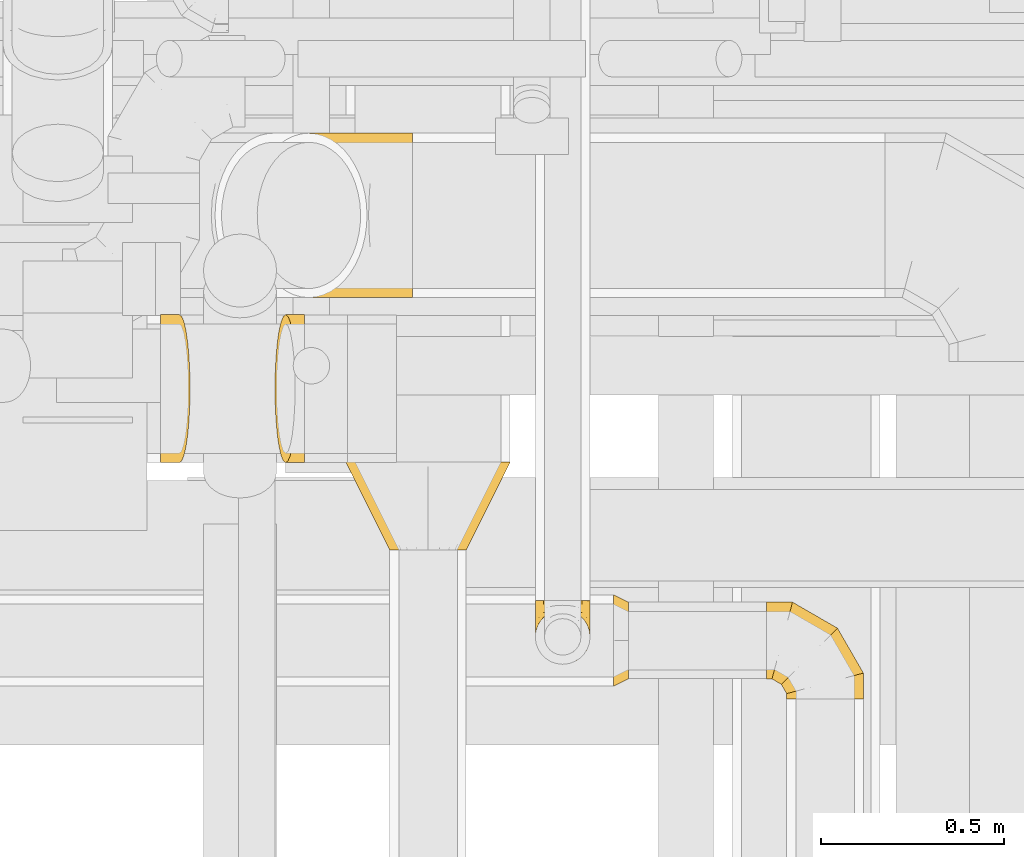
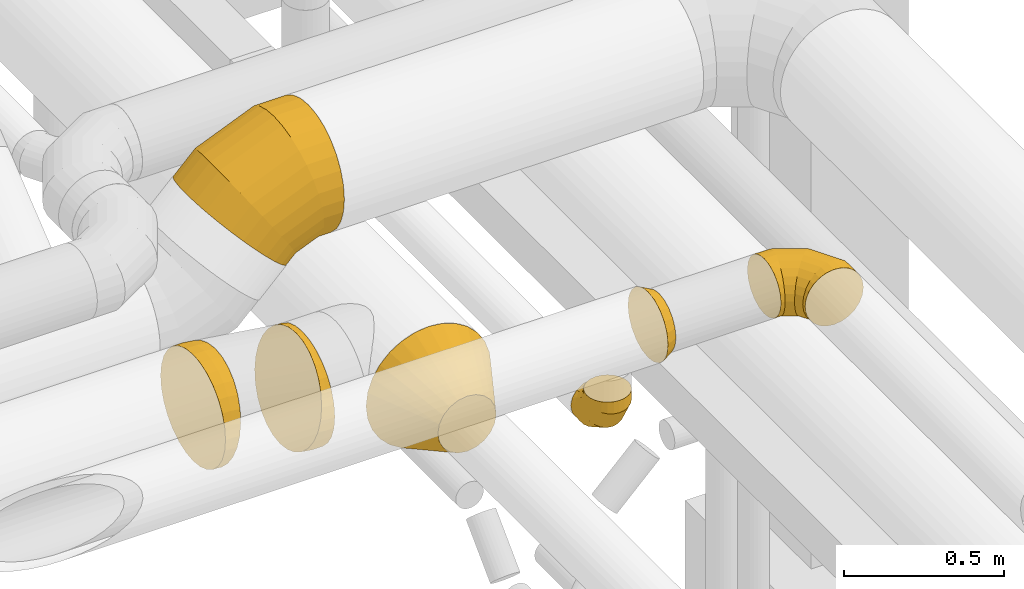
# One storey, part 17 of 337: 7 coverings.
"""IFC2X3 building model written with IfcOpenShell, lengths in millimetres."""

from ifc_helpers import new_model, entity, si_unit, converted_unit, derived_unit, direction, frame, origin, place, context, subcontext, project, spatial, faceted_brep, element, save


model = new_model("IFC2X3")

# Units and contexts
model_context = context("Model", 3, precision=0.01, world=origin(), true_north=direction((6.12303176911189e-17, 1.0)))
body_context = subcontext(model_context, "Body", "Model", "MODEL_VIEW")
ifc_project = project(units=[si_unit("LENGTHUNIT", "METRE", prefix="MILLI"), si_unit("AREAUNIT", "SQUARE_METRE"), si_unit("VOLUMEUNIT", "CUBIC_METRE"), converted_unit("PLANEANGLEUNIT", "DEGREE", entity("IfcRatioMeasure", 0.0174532925199433), si_unit("PLANEANGLEUNIT", "RADIAN"), dimensions=[0, 0, 0, 0, 0, 0, 0]), si_unit("MASSUNIT", "GRAM", prefix="KILO"), derived_unit("MASSDENSITYUNIT", [(si_unit("MASSUNIT", "GRAM", prefix="KILO"), 1), (si_unit("LENGTHUNIT", "METRE"), -3)]), derived_unit("MOMENTOFINERTIAUNIT", [(si_unit("LENGTHUNIT", "METRE"), 4)]), si_unit("TIMEUNIT", "SECOND"), si_unit("FREQUENCYUNIT", "HERTZ"), si_unit("THERMODYNAMICTEMPERATUREUNIT", "DEGREE_CELSIUS"), derived_unit("THERMALTRANSMITTANCEUNIT", [(si_unit("MASSUNIT", "GRAM", prefix="KILO"), 1), (si_unit("THERMODYNAMICTEMPERATUREUNIT", "KELVIN"), -1), (si_unit("TIMEUNIT", "SECOND"), -3)]), derived_unit("VOLUMETRICFLOWRATEUNIT", [(si_unit("LENGTHUNIT", "METRE"), 3), (si_unit("TIMEUNIT", "SECOND"), -1)]), derived_unit("MASSFLOWRATEUNIT", [(si_unit("MASSUNIT", "GRAM", prefix="KILO"), 1), (si_unit("TIMEUNIT", "SECOND"), -1)]), derived_unit("ROTATIONALFREQUENCYUNIT", [(si_unit("TIMEUNIT", "SECOND"), -1)]), si_unit("ELECTRICCURRENTUNIT", "AMPERE"), si_unit("ELECTRICVOLTAGEUNIT", "VOLT"), si_unit("POWERUNIT", "WATT"), si_unit("FORCEUNIT", "NEWTON", prefix="KILO"), si_unit("ILLUMINANCEUNIT", "LUX"), si_unit("LUMINOUSFLUXUNIT", "LUMEN"), si_unit("LUMINOUSINTENSITYUNIT", "CANDELA"), derived_unit("USERDEFINED", [(si_unit("MASSUNIT", "GRAM", prefix="KILO"), -1), (si_unit("LENGTHUNIT", "METRE"), -2), (si_unit("TIMEUNIT", "SECOND"), 3), (si_unit("LUMINOUSFLUXUNIT", "LUMEN"), 1)]), derived_unit("LINEARVELOCITYUNIT", [(si_unit("LENGTHUNIT", "METRE"), 1), (si_unit("TIMEUNIT", "SECOND"), -1)]), si_unit("PRESSUREUNIT", "PASCAL"), derived_unit("USERDEFINED", [(si_unit("LENGTHUNIT", "METRE"), -2), (si_unit("MASSUNIT", "GRAM", prefix="KILO"), 1), (si_unit("TIMEUNIT", "SECOND"), -2)]), derived_unit("LINEARFORCEUNIT", [(si_unit("MASSUNIT", "GRAM", prefix="KILO"), 1), (si_unit("LENGTHUNIT", "METRE"), 1), (si_unit("TIMEUNIT", "SECOND"), -2), (si_unit("LENGTHUNIT", "METRE"), -1)]), derived_unit("PLANARFORCEUNIT", [(si_unit("MASSUNIT", "GRAM", prefix="KILO"), 1), (si_unit("LENGTHUNIT", "METRE"), 1), (si_unit("TIMEUNIT", "SECOND"), -2), (si_unit("LENGTHUNIT", "METRE"), -2)])], contexts=[model_context])

# Site, building, storey
site_placement = place(None, origin())
site = spatial("IfcSite", under=ifc_project, at=site_placement, CompositionType="ELEMENT")
building_placement = place(site_placement, origin())
building = spatial("IfcBuilding", under=site, at=building_placement, CompositionType="ELEMENT")
storey_placement = place(building_placement, origin())
storey = spatial("IfcBuildingStorey", under=building, at=storey_placement, CompositionType="ELEMENT", Elevation=0.0)

# Coverings
covering_1_placement = place(storey_placement, frame((64421.67, 8834.91, 2823.4)))
element("IfcCovering", 1, at=covering_1_placement, inside=storey, PredefinedType="INSULATION", context=body_context, shape_type="Brep", body=[
    faceted_brep([(276.66, 240.0, 445.95), (324.22, 240.0, 429.31), (366.88, 240.0, 402.51), (402.51, 240.0, 366.88), (429.31, 240.0, 324.22), (445.95, 240.0, 276.66), (451.6, 240.0, 226.6), (445.95, 240.0, 176.53), (429.31, 240.0, 128.97), (402.51, 240.0, 86.31), (366.88, 240.0, 50.68), (324.22, 240.0, 23.88), (276.66, 240.0, 7.24), (226.6, 240.0, 1.6), (176.53, 240.0, 7.24), (128.97, 240.0, 23.88), (86.31, 240.0, 50.68), (50.68, 240.0, 86.31), (23.88, 240.0, 128.97), (7.24, 240.0, 176.53), (1.6, 240.0, 226.6), (7.24, 240.0, 276.66), (23.88, 240.0, 324.22), (50.68, 240.0, 366.88), (86.31, 240.0, 402.51), (128.97, 240.0, 429.31), (176.53, 240.0, 445.95), (226.6, 240.0, 451.6), (259.04, 0.0, 326.46), (226.6, 0.0, 331.6), (194.15, 0.0, 326.46), (164.88, 0.0, 311.54), (141.65, 0.0, 288.31), (126.73, 0.0, 259.04), (121.6, 0.0, 226.6), (126.73, 0.0, 194.15), (141.65, 0.0, 164.88), (164.88, 0.0, 141.65), (194.15, 0.0, 126.73), (226.6, 0.0, 121.6), (259.04, 0.0, 126.73), (288.31, 0.0, 141.65), (311.54, 0.0, 164.88), (326.46, 0.0, 194.15), (331.6, 0.0, 226.6), (326.46, 0.0, 259.04), (311.54, 0.0, 288.31), (288.31, 0.0, 311.54)], [[[0, 1, 2, 3, 4, 5, 6, 7, 8, 9, 10, 11, 12, 13, 14, 15, 16, 17, 18, 19, 20, 21, 22, 23, 24, 25, 26, 27]], [[28, 29, 30, 31, 32, 33, 34, 35, 36, 37, 38, 39, 40, 41, 42, 43, 44, 45, 46, 47]], [[43, 42, 8]], [[44, 43, 7]], [[7, 6, 44]], [[9, 8, 42]], [[7, 43, 8]], [[42, 41, 10, 9]], [[11, 41, 40]], [[12, 40, 39]], [[10, 41, 11]], [[11, 40, 12]], [[39, 13, 12]], [[38, 37, 15]], [[39, 38, 14]], [[14, 13, 39]], [[16, 15, 37]], [[14, 38, 15]], [[37, 36, 17, 16]], [[18, 36, 35]], [[19, 35, 34]], [[17, 36, 18]], [[18, 35, 19]], [[34, 20, 19]], [[33, 32, 22]], [[34, 33, 21]], [[21, 20, 34]], [[23, 22, 32]], [[21, 33, 22]], [[32, 31, 24, 23]], [[25, 31, 30]], [[26, 30, 29]], [[24, 31, 25]], [[25, 30, 26]], [[29, 27, 26]], [[28, 47, 1]], [[29, 28, 0]], [[0, 27, 29]], [[2, 1, 47]], [[0, 28, 1]], [[47, 46, 3, 2]], [[4, 46, 45]], [[5, 45, 44]], [[3, 46, 4]], [[4, 45, 5]], [[44, 6, 5]]]),
])
covering_2_placement = place(storey_placement, frame((64161.62, 9523.4, 3222.15)))
element("IfcCovering", 2, at=covering_2_placement, inside=storey, PredefinedType="INSULATION", context=body_context, shape_type="Brep", body=[
    faceted_brep([(315.8, 176.53, 5.58), (304.04, 128.97, 17.35), (285.08, 86.31, 36.31), (259.89, 50.68, 61.5), (229.72, 23.88, 91.66), (196.1, 7.24, 125.29), (160.69, 1.6, 160.69), (125.29, 7.24, 196.1), (91.66, 23.88, 229.72), (61.5, 50.68, 259.89), (36.31, 86.31, 285.08), (17.35, 128.97, 304.04), (5.58, 176.53, 315.8), (1.6, 226.6, 319.79), (5.58, 276.66, 315.8), (17.35, 324.22, 304.04), (36.31, 366.88, 285.08), (61.5, 402.51, 259.89), (91.66, 429.31, 229.72), (125.29, 445.95, 196.1), (160.69, 451.6, 160.69), (196.1, 445.95, 125.29), (229.72, 429.31, 91.66), (259.89, 402.51, 61.5), (285.08, 366.88, 36.31), (304.04, 324.22, 17.35), (315.8, 276.66, 5.58), (319.79, 226.6, 1.6), (443.54, 366.88, 453.76), (443.54, 324.22, 480.57), (443.54, 276.66, 497.21), (443.54, 226.6, 502.85), (443.54, 176.53, 497.21), (443.54, 128.97, 480.57), (443.54, 86.31, 453.76), (443.54, 50.68, 418.14), (443.54, 23.88, 375.48), (443.54, 7.24, 327.92), (443.54, 1.6, 277.85), (443.54, 7.24, 227.78), (443.54, 23.88, 180.23), (443.54, 50.68, 137.57), (443.54, 86.31, 101.94), (443.54, 128.97, 75.13), (443.54, 176.53, 58.49), (443.54, 226.6, 52.85), (443.54, 276.66, 58.49), (443.54, 324.22, 75.13), (443.54, 366.88, 101.94), (443.54, 402.51, 137.57), (443.54, 429.31, 180.23), (443.54, 445.95, 227.78), (443.54, 451.6, 277.85), (443.54, 445.95, 327.92), (443.54, 429.31, 375.48), (443.54, 402.51, 418.14), (319.22, 226.6, 502.85), (320.34, 176.53, 497.21), (323.65, 128.97, 480.57), (328.98, 86.31, 453.76), (336.07, 50.68, 418.14), (344.55, 23.88, 375.48), (354.01, 7.24, 327.92), (363.97, 1.6, 277.85), (373.93, 7.24, 227.78), (383.39, 23.88, 180.23), (391.88, 50.68, 137.57), (398.96, 86.31, 101.94), (404.3, 128.97, 75.13), (407.61, 176.53, 58.49), (408.73, 226.6, 52.85), (407.61, 276.66, 58.49), (404.3, 324.22, 75.13), (398.96, 366.88, 101.94), (391.88, 402.51, 137.57), (383.39, 429.31, 180.23), (373.93, 445.95, 227.78), (363.97, 451.6, 277.85), (354.01, 445.95, 327.92), (344.55, 429.31, 375.48), (336.07, 402.51, 418.14), (328.98, 366.88, 453.76), (323.65, 324.22, 480.57), (320.34, 276.66, 497.21), (89.5, 226.6, 407.7), (92.7, 176.53, 402.92), (102.12, 128.97, 388.81), (117.31, 86.31, 366.09), (137.49, 50.68, 335.88), (161.66, 23.88, 299.72), (188.59, 7.24, 259.4), (216.96, 1.6, 216.96), (245.32, 7.24, 174.51), (272.25, 23.88, 134.19), (296.42, 50.68, 98.03), (316.6, 86.31, 67.82), (331.79, 128.97, 45.1), (341.21, 176.53, 30.99), (344.41, 226.6, 26.21), (341.21, 276.66, 30.99), (331.79, 324.22, 45.1), (316.6, 366.88, 67.82), (296.42, 402.51, 98.03), (272.25, 429.31, 134.19), (245.32, 445.95, 174.51), (216.96, 451.6, 216.96), (188.59, 445.95, 259.4), (161.66, 429.31, 299.72), (137.49, 402.51, 335.88), (117.31, 366.88, 366.09), (102.12, 324.22, 388.81), (92.7, 276.66, 402.92)], [[[0, 1, 2, 3, 4, 5, 6, 7, 8, 9, 10, 11, 12, 13, 14, 15, 16, 17, 18, 19, 20, 21, 22, 23, 24, 25, 26, 27]], [[28, 29, 30, 31, 32, 33, 34, 35, 36, 37, 38, 39, 40, 41, 42, 43, 44, 45, 46, 47, 48, 49, 50, 51, 52, 53, 54, 55]], [[31, 56, 57, 32]], [[32, 57, 58, 33]], [[33, 58, 59, 34]], [[59, 60, 35, 34]], [[35, 60, 61, 36]], [[36, 61, 62, 37]], [[37, 62, 63, 38]], [[63, 64, 39, 38]], [[65, 66, 41, 40]], [[64, 65, 40, 39]], [[66, 67, 42, 41]], [[67, 68, 43, 42]], [[69, 70, 45, 44]], [[68, 69, 44, 43]], [[70, 71, 46, 45]], [[72, 73, 48, 47]], [[71, 72, 47, 46]], [[73, 74, 49, 48]], [[74, 75, 50, 49]], [[76, 77, 52, 51]], [[75, 76, 51, 50]], [[53, 52, 77, 78]], [[78, 79, 54, 53]], [[80, 55, 54, 79]], [[80, 81, 28, 55]], [[29, 28, 81, 82]], [[82, 83, 30, 29]], [[56, 31, 30, 83]], [[56, 84, 85, 57]], [[57, 85, 86, 58]], [[59, 58, 86, 87]], [[87, 88, 60, 59]], [[61, 60, 88, 89]], [[62, 61, 89, 90]], [[63, 62, 90, 91]], [[91, 92, 64, 63]], [[93, 94, 66, 65]], [[92, 93, 65, 64]], [[94, 95, 67, 66]], [[95, 96, 68, 67]], [[97, 98, 70, 69]], [[96, 97, 69, 68]], [[98, 99, 71, 70]], [[100, 101, 73, 72]], [[99, 100, 72, 71]], [[101, 102, 74, 73]], [[102, 103, 75, 74]], [[104, 105, 77, 76]], [[103, 104, 76, 75]], [[78, 77, 105, 106]], [[106, 107, 79, 78]], [[108, 80, 79, 107]], [[108, 109, 81, 80]], [[82, 81, 109, 110]], [[110, 111, 83, 82]], [[84, 56, 83, 111]], [[85, 84, 13, 12]], [[11, 10, 87, 86]], [[86, 85, 12, 11]], [[10, 9, 88, 87]], [[89, 88, 9, 8]], [[90, 89, 8, 7]], [[91, 90, 7, 6]], [[92, 91, 6, 5]], [[5, 4, 93, 92]], [[3, 94, 93, 4]], [[3, 2, 95, 94]], [[2, 1, 96, 95]], [[1, 0, 97, 96]], [[98, 97, 0, 27]], [[98, 27, 26, 99]], [[26, 25, 100, 99]], [[24, 101, 100, 25]], [[24, 23, 102, 101]], [[102, 23, 22, 103]], [[21, 20, 105, 104]], [[103, 22, 21, 104]], [[105, 20, 19, 106]], [[106, 19, 18, 107]], [[107, 18, 17, 108]], [[17, 16, 109, 108]], [[109, 16, 15, 110]], [[110, 15, 14, 111]], [[111, 14, 13, 84]]]),
])
covering_3_placement = place(storey_placement, frame((63916.47, 9071.79, 2894.3)))
element("IfcCovering", 3, at=covering_3_placement, inside=storey, PredefinedType="INSULATION", context=body_context, shape_type="Brep", body=[
    faceted_brep([(0.0, 204.1, 3.2), (0.0, 159.03, 8.28), (0.0, 116.23, 23.25), (0.0, 77.84, 47.38), (0.0, 45.77, 79.44), (0.0, 21.65, 117.84), (0.0, 6.67, 160.64), (0.0, 1.6, 205.7), (0.0, 6.67, 250.76), (0.0, 21.65, 293.56), (0.0, 45.77, 331.96), (0.0, 77.84, 364.02), (0.0, 116.23, 388.14), (0.0, 159.03, 403.12), (0.0, 204.1, 408.2), (0.0, 249.16, 403.12), (0.0, 291.96, 388.14), (0.0, 330.35, 364.02), (0.0, 362.42, 331.96), (0.0, 386.54, 293.56), (0.0, 401.52, 250.76), (0.0, 406.6, 205.7), (0.0, 401.52, 160.64), (0.0, 386.54, 117.84), (0.0, 362.42, 79.44), (0.0, 330.35, 47.38), (0.0, 291.96, 23.25), (0.0, 249.16, 8.28), (74.24, 330.35, 358.62), (77.73, 291.96, 382.49), (79.9, 249.16, 397.31), (80.63, 204.1, 402.34), (79.9, 159.03, 397.31), (77.73, 116.23, 382.49), (74.24, 77.84, 358.62), (69.6, 45.77, 326.9), (64.05, 21.65, 288.9), (57.86, 6.67, 246.55), (51.34, 1.6, 201.97), (44.83, 6.67, 157.38), (38.64, 21.65, 115.03), (33.08, 45.77, 77.04), (28.45, 77.84, 45.31), (24.96, 116.23, 21.44), (22.79, 159.03, 6.62), (22.06, 204.1, 1.6), (22.79, 249.16, 6.62), (24.96, 291.96, 21.44), (28.45, 330.35, 45.31), (33.08, 362.42, 77.04), (38.64, 386.54, 115.03), (44.83, 401.52, 157.38), (51.34, 406.6, 201.97), (57.86, 401.52, 246.55), (64.05, 386.54, 288.9), (69.6, 362.42, 326.9), (40.53, 204.1, 408.2), (40.16, 159.03, 403.12), (39.07, 116.23, 388.14), (37.32, 77.84, 364.02), (34.99, 45.77, 331.96), (32.19, 21.65, 293.56), (29.08, 6.67, 250.76), (25.81, 1.6, 205.7), (22.53, 6.67, 160.64), (19.42, 21.65, 117.84), (16.63, 45.77, 79.44), (14.3, 77.84, 47.38), (12.54, 116.23, 23.25), (11.46, 159.03, 8.28), (11.09, 204.1, 3.2), (11.46, 249.16, 8.28), (12.54, 291.96, 23.25), (14.3, 330.35, 47.38), (16.63, 362.42, 79.44), (19.42, 386.54, 117.84), (22.53, 401.52, 160.64), (25.81, 406.6, 205.7), (29.08, 401.52, 250.76), (32.19, 386.54, 293.56), (34.99, 362.42, 331.96), (37.32, 330.35, 364.02), (39.07, 291.96, 388.14), (40.16, 249.16, 403.12)], [[[0, 1, 2, 3, 4, 5, 6, 7, 8, 9, 10, 11, 12, 13, 14, 15, 16, 17, 18, 19, 20, 21, 22, 23, 24, 25, 26, 27]], [[28, 29, 30, 31, 32, 33, 34, 35, 36, 37, 38, 39, 40, 41, 42, 43, 44, 45, 46, 47, 48, 49, 50, 51, 52, 53, 54, 55]], [[31, 56, 57, 32]], [[32, 57, 58, 33]], [[33, 58, 59, 34]], [[59, 60, 35, 34]], [[35, 60, 61, 36]], [[36, 61, 62, 37]], [[37, 62, 63, 38]], [[63, 64, 39, 38]], [[65, 66, 41, 40]], [[64, 65, 40, 39]], [[66, 67, 42, 41]], [[67, 68, 43, 42]], [[69, 70, 45, 44]], [[68, 69, 44, 43]], [[70, 71, 46, 45]], [[72, 73, 48, 47]], [[71, 72, 47, 46]], [[73, 74, 49, 48]], [[74, 75, 50, 49]], [[76, 77, 52, 51]], [[75, 76, 51, 50]], [[53, 52, 77, 78]], [[78, 79, 54, 53]], [[80, 55, 54, 79]], [[80, 81, 28, 55]], [[29, 28, 81, 82]], [[82, 83, 30, 29]], [[56, 31, 30, 83]], [[57, 56, 14, 13]], [[13, 12, 58, 57]], [[11, 59, 58, 12]], [[11, 10, 60, 59]], [[10, 9, 61, 60]], [[9, 8, 62, 61]], [[63, 62, 8, 7]], [[64, 63, 7, 6]], [[6, 5, 65, 64]], [[4, 66, 65, 5]], [[4, 3, 67, 66]], [[3, 2, 68, 67]], [[1, 0, 70, 69]], [[2, 1, 69, 68]], [[70, 0, 27, 71]], [[27, 26, 72, 71]], [[25, 73, 72, 26]], [[25, 24, 74, 73]], [[74, 24, 23, 75]], [[75, 23, 22, 76]], [[76, 22, 21, 77]], [[77, 21, 20, 78]], [[20, 19, 79, 78]], [[18, 80, 79, 19]], [[18, 17, 81, 80]], [[81, 17, 16, 82]], [[16, 15, 83, 82]], [[14, 56, 83, 15]]]),
])
covering_4_placement = place(storey_placement, frame((64227.94, 9071.79, 2845.9)))
element("IfcCovering", 4, at=covering_4_placement, inside=storey, PredefinedType="INSULATION", context=body_context, shape_type="Brep", body=[
    faceted_brep([(60.17, 204.1, 408.2), (59.44, 249.16, 403.17), (57.27, 291.96, 388.36), (53.78, 330.35, 364.48), (49.14, 362.42, 332.76), (43.59, 386.54, 294.77), (37.4, 401.52, 252.41), (30.88, 406.6, 207.83), (24.37, 401.52, 163.24), (18.18, 386.54, 120.89), (12.62, 362.42, 82.9), (7.98, 330.35, 51.17), (4.5, 291.96, 27.3), (2.33, 249.16, 12.48), (1.6, 204.1, 7.46), (2.33, 159.03, 12.48), (4.5, 116.23, 27.3), (7.98, 77.84, 51.17), (12.62, 45.77, 82.9), (18.18, 21.65, 120.89), (24.37, 6.67, 163.24), (30.88, 1.6, 207.83), (37.4, 6.67, 252.41), (43.59, 21.65, 294.77), (49.14, 45.77, 332.76), (53.78, 77.84, 364.48), (57.27, 116.23, 388.36), (59.44, 159.03, 403.17), (82.23, 77.84, 45.77), (82.23, 116.23, 21.65), (82.23, 159.03, 6.67), (82.23, 204.1, 1.6), (82.23, 249.16, 6.67), (82.23, 291.96, 21.65), (82.23, 330.35, 45.77), (82.23, 362.42, 77.84), (82.23, 386.54, 116.23), (82.23, 401.52, 159.03), (82.23, 406.6, 204.1), (82.23, 401.52, 249.16), (82.23, 386.54, 291.96), (82.23, 362.42, 330.35), (82.23, 330.35, 362.42), (82.23, 291.96, 386.54), (82.23, 249.16, 401.52), (82.23, 204.1, 406.6), (82.23, 159.03, 401.52), (82.23, 116.23, 386.54), (82.23, 77.84, 362.42), (82.23, 45.77, 330.35), (82.23, 21.65, 291.96), (82.23, 6.67, 249.16), (82.23, 1.6, 204.1), (82.23, 6.67, 159.03), (82.23, 21.65, 116.23), (82.23, 45.77, 77.84), (41.7, 204.1, 1.6), (42.07, 249.16, 6.67), (43.16, 291.96, 21.65), (44.91, 330.35, 45.77), (47.24, 362.42, 77.84), (50.03, 386.54, 116.23), (53.14, 401.52, 159.03), (56.42, 406.6, 204.1), (59.69, 401.52, 249.16), (62.81, 386.54, 291.96), (65.6, 362.42, 330.35), (67.93, 330.35, 362.42), (69.68, 291.96, 386.54), (70.77, 249.16, 401.52), (71.14, 204.1, 406.6), (70.77, 159.03, 401.52), (69.68, 116.23, 386.54), (67.93, 77.84, 362.42), (65.6, 45.77, 330.35), (62.81, 21.65, 291.96), (59.69, 6.67, 249.16), (56.42, 1.6, 204.1), (53.14, 6.67, 159.03), (50.03, 21.65, 116.23), (47.24, 45.77, 77.84), (44.91, 77.84, 45.77), (43.16, 116.23, 21.65), (42.07, 159.03, 6.67)], [[[0, 1, 2, 3, 4, 5, 6, 7, 8, 9, 10, 11, 12, 13, 14, 15, 16, 17, 18, 19, 20, 21, 22, 23, 24, 25, 26, 27]], [[28, 29, 30, 31, 32, 33, 34, 35, 36, 37, 38, 39, 40, 41, 42, 43, 44, 45, 46, 47, 48, 49, 50, 51, 52, 53, 54, 55]], [[31, 56, 57, 32]], [[32, 57, 58, 33]], [[33, 58, 59, 34]], [[59, 60, 35, 34]], [[35, 60, 61, 36]], [[36, 61, 62, 37]], [[37, 62, 63, 38]], [[63, 64, 39, 38]], [[65, 66, 41, 40]], [[64, 65, 40, 39]], [[66, 67, 42, 41]], [[67, 68, 43, 42]], [[69, 70, 45, 44]], [[68, 69, 44, 43]], [[70, 71, 46, 45]], [[72, 73, 48, 47]], [[71, 72, 47, 46]], [[73, 74, 49, 48]], [[74, 75, 50, 49]], [[76, 77, 52, 51]], [[75, 76, 51, 50]], [[53, 52, 77, 78]], [[78, 79, 54, 53]], [[80, 55, 54, 79]], [[80, 81, 28, 55]], [[29, 28, 81, 82]], [[82, 83, 30, 29]], [[56, 31, 30, 83]], [[57, 56, 14, 13]], [[13, 12, 58, 57]], [[11, 59, 58, 12]], [[11, 10, 60, 59]], [[10, 9, 61, 60]], [[9, 8, 62, 61]], [[63, 62, 8, 7]], [[64, 63, 7, 6]], [[6, 5, 65, 64]], [[4, 66, 65, 5]], [[4, 3, 67, 66]], [[3, 2, 68, 67]], [[1, 0, 70, 69]], [[2, 1, 69, 68]], [[70, 0, 27, 71]], [[27, 26, 72, 71]], [[25, 73, 72, 26]], [[25, 24, 74, 73]], [[74, 24, 23, 75]], [[75, 23, 22, 76]], [[76, 22, 21, 77]], [[77, 21, 20, 78]], [[20, 19, 79, 78]], [[18, 80, 79, 19]], [[18, 17, 81, 80]], [[81, 17, 16, 82]], [[16, 15, 83, 82]], [[14, 56, 83, 15]]]),
])
covering_5_placement = place(storey_placement, frame((65156.4, 8460.07, 3273.4)))
element("IfcCovering", 5, at=covering_5_placement, inside=storey, PredefinedType="INSULATION", context=body_context, shape_type="Brep", body=[
    faceted_brep([(40.0, 159.04, 226.46), (40.0, 126.6, 231.6), (40.0, 94.15, 226.46), (40.0, 64.88, 211.54), (40.0, 41.65, 188.31), (40.0, 26.73, 159.04), (40.0, 21.6, 126.6), (40.0, 26.73, 94.15), (40.0, 41.65, 64.88), (40.0, 64.88, 41.65), (40.0, 94.15, 26.73), (40.0, 126.6, 21.6), (40.0, 159.04, 26.73), (40.0, 188.31, 41.65), (40.0, 211.54, 64.88), (40.0, 226.46, 94.15), (40.0, 231.6, 126.6), (40.0, 226.46, 159.04), (40.0, 211.54, 188.31), (40.0, 188.31, 211.54), (0.0, 251.6, 126.6), (0.0, 245.48, 87.97), (0.0, 227.72, 53.12), (0.0, 200.07, 25.47), (0.0, 165.22, 7.71), (0.0, 126.6, 1.6), (0.0, 87.97, 7.71), (0.0, 53.12, 25.47), (0.0, 25.47, 53.12), (0.0, 7.71, 87.97), (0.0, 1.6, 126.6), (0.0, 7.71, 165.22), (0.0, 25.47, 200.07), (0.0, 53.12, 227.72), (0.0, 87.97, 245.48), (0.0, 126.6, 251.6), (0.0, 165.22, 245.48), (0.0, 200.07, 227.72), (0.0, 227.72, 200.07), (0.0, 245.48, 165.22)], [[[0, 1, 2, 3, 4, 5, 6, 7, 8, 9, 10, 11, 12, 13, 14, 15, 16, 17, 18, 19]], [[20, 21, 22, 23, 24, 25, 26, 27, 28, 29, 30, 31, 32, 33, 34, 35, 36, 37, 38, 39]], [[26, 25, 11, 10]], [[26, 10, 9, 27]], [[9, 8, 28, 27]], [[7, 6, 30, 29]], [[8, 7, 29, 28]], [[21, 20, 16, 15]], [[21, 15, 14, 22]], [[14, 13, 23, 22]], [[12, 11, 25, 24]], [[13, 12, 24, 23]], [[36, 35, 1, 0]], [[36, 0, 19, 37]], [[19, 18, 38, 37]], [[17, 16, 20, 39]], [[18, 17, 39, 38]], [[31, 30, 6, 5]], [[31, 5, 4, 32]], [[4, 3, 33, 32]], [[2, 1, 35, 34]], [[3, 2, 34, 33]]]),
])
covering_6_placement = place(storey_placement, frame((65574.68, 8426.67, 3293.4)))
element("IfcCovering", 6, at=covering_6_placement, inside=storey, PredefinedType="INSULATION", context=body_context, shape_type="Brep", body=[
    faceted_brep([(0.0, 160.0, 211.6), (0.0, 192.45, 206.46), (0.0, 221.72, 191.54), (0.0, 244.95, 168.31), (0.0, 259.86, 139.04), (0.0, 265.0, 106.6), (0.0, 259.86, 74.15), (0.0, 244.95, 44.88), (0.0, 221.72, 21.65), (0.0, 192.45, 6.73), (0.0, 160.0, 1.6), (0.0, 127.55, 6.73), (0.0, 98.28, 21.65), (0.0, 75.05, 44.88), (0.0, 60.14, 74.15), (0.0, 55.0, 106.6), (0.0, 60.14, 139.04), (0.0, 75.05, 168.31), (0.0, 98.28, 191.54), (0.0, 127.55, 206.46), (250.93, 0.0, 54.1), (261.42, 0.0, 79.42), (265.0, 0.0, 106.6), (261.42, 0.0, 133.77), (250.93, 0.0, 159.1), (234.25, 0.0, 180.84), (212.5, 0.0, 197.53), (187.18, 0.0, 208.02), (160.0, 0.0, 211.6), (132.82, 0.0, 208.02), (107.5, 0.0, 197.53), (85.75, 0.0, 180.84), (69.07, 0.0, 159.1), (58.58, 0.0, 133.77), (55.0, 0.0, 106.6), (58.58, 0.0, 79.42), (69.07, 0.0, 54.1), (85.75, 0.0, 32.35), (107.5, 0.0, 15.66), (132.82, 0.0, 5.17), (160.0, 0.0, 1.6), (187.18, 0.0, 5.17), (212.5, 0.0, 15.66), (234.25, 0.0, 32.35), (265.0, 71.01, 106.6), (261.42, 70.05, 133.77), (250.93, 67.24, 159.1), (234.25, 62.77, 180.84), (212.5, 56.94, 197.53), (187.18, 50.15, 208.02), (160.0, 42.87, 211.6), (132.82, 35.59, 208.02), (107.5, 28.8, 197.53), (85.75, 22.98, 180.84), (69.07, 18.51, 159.1), (58.58, 15.7, 133.77), (55.0, 14.74, 106.6), (58.58, 15.7, 79.42), (69.07, 18.51, 54.1), (85.75, 22.98, 32.35), (132.82, 35.59, 5.17), (160.0, 42.87, 1.6), (107.5, 28.8, 15.66), (187.18, 50.15, 5.17), (212.5, 56.94, 15.66), (234.25, 62.77, 32.35), (250.93, 67.24, 54.1), (261.42, 70.05, 79.42), (193.99, 193.99, 106.6), (191.37, 191.37, 133.77), (183.7, 183.7, 159.1), (171.48, 171.48, 180.84), (155.56, 155.56, 197.53), (137.02, 137.02, 208.02), (117.13, 117.13, 211.6), (97.23, 97.23, 208.02), (78.7, 78.7, 197.53), (62.78, 62.78, 180.84), (50.56, 50.56, 159.1), (42.88, 42.88, 133.77), (40.26, 40.26, 106.6), (42.88, 42.88, 79.42), (50.56, 50.56, 54.1), (62.78, 62.78, 32.35), (97.23, 97.23, 5.17), (117.13, 117.13, 1.6), (78.7, 78.7, 15.66), (137.02, 137.02, 5.17), (155.56, 155.56, 15.66), (171.48, 171.48, 32.35), (183.7, 183.7, 54.1), (191.37, 191.37, 79.42), (71.01, 265.0, 106.6), (70.05, 261.42, 133.77), (67.24, 250.93, 159.1), (62.77, 234.25, 180.84), (56.94, 212.5, 197.53), (50.15, 187.18, 208.02), (42.87, 160.0, 211.6), (35.59, 132.82, 208.02), (28.8, 107.5, 197.53), (22.98, 85.75, 180.84), (18.51, 69.07, 159.1), (15.7, 58.58, 133.77), (14.74, 55.0, 106.6), (15.7, 58.58, 79.42), (18.51, 69.07, 54.1), (22.98, 85.75, 32.35), (35.59, 132.82, 5.17), (42.87, 160.0, 1.6), (28.8, 107.5, 15.66), (50.15, 187.18, 5.17), (56.94, 212.5, 15.66), (62.77, 234.25, 32.35), (67.24, 250.93, 54.1), (70.05, 261.42, 79.42)], [[[0, 1, 2, 3, 4, 5, 6, 7, 8, 9, 10, 11, 12, 13, 14, 15, 16, 17, 18, 19]], [[20, 21, 22, 23, 24, 25, 26, 27, 28, 29, 30, 31, 32, 33, 34, 35, 36, 37, 38, 39, 40, 41, 42, 43]], [[22, 44, 45, 23]], [[23, 45, 46, 24]], [[24, 46, 47, 25]], [[25, 47, 48, 26]], [[26, 48, 49, 27]], [[50, 28, 27, 49]], [[51, 52, 30, 29]], [[50, 51, 29, 28]], [[53, 31, 30, 52]], [[54, 55, 33, 32]], [[54, 32, 31, 53]], [[56, 34, 33, 55]], [[57, 58, 36, 35]], [[56, 57, 35, 34]], [[37, 36, 58, 59]], [[60, 61, 40, 39]], [[62, 60, 39, 38]], [[59, 62, 38, 37]], [[41, 40, 61, 63]], [[42, 41, 63, 64]], [[64, 65, 43, 42]], [[21, 20, 66, 67]], [[22, 21, 67, 44]], [[65, 66, 20, 43]], [[45, 44, 68, 69]], [[46, 45, 69, 70]], [[70, 71, 47, 46]], [[48, 47, 71, 72]], [[49, 48, 72, 73]], [[50, 49, 73, 74]], [[75, 76, 52, 51]], [[74, 75, 51, 50]], [[53, 52, 76, 77]], [[78, 79, 55, 54]], [[77, 78, 54, 53]], [[56, 55, 79, 80]], [[81, 82, 58, 57]], [[80, 81, 57, 56]], [[59, 58, 82, 83]], [[84, 85, 61, 60]], [[86, 84, 60, 62]], [[83, 86, 62, 59]], [[63, 61, 85, 87]], [[64, 63, 87, 88]], [[65, 64, 88, 89]], [[67, 66, 90, 91]], [[44, 67, 91, 68]], [[89, 90, 66, 65]], [[69, 68, 92, 93]], [[70, 69, 93, 94]], [[94, 95, 71, 70]], [[72, 71, 95, 96]], [[73, 72, 96, 97]], [[74, 73, 97, 98]], [[99, 100, 76, 75]], [[98, 99, 75, 74]], [[77, 76, 100, 101]], [[102, 103, 79, 78]], [[101, 102, 78, 77]], [[80, 79, 103, 104]], [[105, 106, 82, 81]], [[104, 105, 81, 80]], [[83, 82, 106, 107]], [[108, 109, 85, 84]], [[110, 108, 84, 86]], [[107, 110, 86, 83]], [[87, 85, 109, 111]], [[88, 87, 111, 112]], [[89, 88, 112, 113]], [[91, 90, 114, 115]], [[68, 91, 115, 92]], [[113, 114, 90, 89]], [[93, 5, 4]], [[94, 4, 3]], [[5, 93, 92]], [[93, 4, 94]], [[3, 95, 94]], [[96, 2, 1]], [[97, 1, 0]], [[95, 2, 96]], [[96, 1, 97]], [[0, 98, 97]], [[2, 95, 3]], [[99, 0, 19]], [[100, 19, 18]], [[99, 98, 0]], [[100, 99, 19]], [[18, 101, 100]], [[102, 17, 16]], [[103, 16, 15]], [[102, 101, 17]], [[104, 103, 15]], [[102, 16, 103]], [[17, 101, 18]], [[105, 15, 14]], [[106, 14, 13]], [[105, 104, 15]], [[106, 105, 14]], [[13, 107, 106]], [[110, 12, 11]], [[108, 11, 10]], [[110, 107, 12]], [[109, 108, 10]], [[110, 11, 108]], [[12, 107, 13]], [[9, 8, 112]], [[10, 9, 111]], [[10, 111, 109]], [[111, 9, 112]], [[8, 113, 112]], [[114, 7, 6]], [[115, 6, 5]], [[113, 7, 114]], [[115, 114, 6]], [[92, 115, 5]], [[7, 113, 8]]]),
])
covering_7_placement = place(storey_placement, frame((64940.15, 8520.07, 3023.4)))
element("IfcCovering", 7, at=covering_7_placement, inside=storey, PredefinedType="INSULATION", context=body_context, shape_type="Brep", body=[
    faceted_brep([(105.3, 176.6, 7.3), (90.95, 176.6, 4.45), (76.6, 176.6, 1.6), (62.24, 176.6, 4.45), (47.89, 176.6, 7.3), (35.73, 176.6, 15.43), (23.56, 176.6, 23.56), (15.43, 176.6, 35.73), (7.3, 176.6, 47.89), (4.45, 176.6, 62.24), (1.6, 176.6, 76.6), (4.45, 176.6, 90.95), (7.3, 176.6, 105.3), (15.43, 176.6, 117.46), (23.56, 176.6, 129.63), (35.73, 176.6, 137.76), (47.89, 176.6, 145.89), (62.24, 176.6, 148.74), (69.42, 176.6, 150.17), (76.6, 176.6, 151.6), (83.77, 176.6, 150.17), (90.95, 176.6, 148.74), (105.3, 176.6, 145.89), (117.46, 176.6, 137.76), (129.63, 176.6, 129.63), (137.76, 176.6, 117.46), (145.89, 176.6, 105.3), (148.74, 176.6, 90.95), (151.6, 176.6, 76.6), (148.74, 176.6, 62.24), (145.89, 176.6, 47.89), (137.76, 176.6, 35.73), (129.63, 176.6, 23.56), (117.46, 176.6, 15.43), (57.18, 4.15, 176.6), (76.6, 1.6, 176.6), (96.01, 4.15, 176.6), (114.1, 11.64, 176.6), (129.63, 23.56, 176.6), (141.55, 39.1, 176.6), (149.04, 57.18, 176.6), (151.6, 76.6, 176.6), (149.04, 96.01, 176.6), (141.55, 114.1, 176.6), (129.63, 129.63, 176.6), (114.1, 141.55, 176.6), (96.01, 149.04, 176.6), (76.6, 151.6, 176.6), (57.18, 149.04, 176.6), (39.1, 141.55, 176.6), (23.56, 129.63, 176.6), (11.64, 114.1, 176.6), (4.15, 96.01, 176.6), (1.6, 76.6, 176.6), (4.15, 57.18, 176.6), (11.64, 39.1, 176.6), (23.56, 23.56, 176.6), (39.1, 11.64, 176.6), (76.6, 1.6, 129.7), (96.01, 4.15, 130.39), (114.1, 11.64, 132.4), (129.63, 23.56, 135.59), (141.55, 39.1, 139.75), (149.04, 57.18, 144.6), (151.6, 76.6, 149.8), (149.04, 96.01, 155.0), (141.55, 114.1, 159.85), (129.63, 129.63, 164.01), (114.1, 141.55, 167.2), (96.01, 149.04, 169.21), (76.6, 151.6, 169.9), (57.18, 149.04, 169.21), (39.1, 141.55, 167.2), (23.56, 129.63, 164.01), (4.15, 96.01, 155.0), (1.6, 76.6, 149.8), (11.64, 114.1, 159.85), (4.15, 57.18, 144.6), (11.64, 39.1, 139.75), (23.56, 23.56, 135.59), (39.1, 11.64, 132.4), (57.18, 4.15, 130.39), (76.6, 48.49, 48.49), (96.01, 50.36, 50.36), (114.1, 55.84, 55.84), (129.63, 64.57, 64.57), (141.55, 75.94, 75.94), (149.04, 89.18, 89.18), (151.6, 103.39, 103.39), (149.04, 117.6, 117.6), (141.55, 130.84, 130.84), (129.63, 142.21, 142.21), (114.1, 150.94, 150.94), (96.01, 156.42, 156.42), (76.6, 158.29, 158.29), (57.18, 156.42, 156.42), (39.1, 150.94, 150.94), (23.56, 142.21, 142.21), (4.15, 117.6, 117.6), (1.6, 103.39, 103.39), (11.64, 130.84, 130.84), (4.15, 89.18, 89.18), (11.64, 75.94, 75.94), (23.56, 64.57, 64.57), (39.1, 55.84, 55.84), (57.18, 50.36, 50.36), (76.6, 129.7, 1.6), (96.01, 130.39, 4.15), (114.1, 132.4, 11.64), (129.63, 135.59, 23.56), (141.55, 139.75, 39.1), (149.04, 144.6, 57.18), (151.6, 149.8, 76.6), (149.04, 155.0, 96.01), (141.55, 159.85, 114.1), (129.63, 164.01, 129.63), (114.1, 167.2, 141.55), (105.05, 168.21, 145.29), (96.01, 169.21, 149.04), (86.3, 169.55, 150.32), (76.6, 169.9, 151.6), (57.18, 169.21, 149.04), (48.14, 168.21, 145.29), (39.1, 167.2, 141.55), (66.89, 169.55, 150.32), (23.56, 164.01, 129.63), (4.15, 155.0, 96.01), (1.6, 149.8, 76.6), (11.64, 159.85, 114.1), (4.15, 144.6, 57.18), (11.64, 139.75, 39.1), (23.56, 135.59, 23.56), (39.1, 132.4, 11.64), (57.18, 130.39, 4.15)], [[[0, 1, 2, 3, 4, 5, 6, 7, 8, 9, 10, 11, 12, 13, 14, 15, 16, 17, 18, 19, 20, 21, 22, 23, 24, 25, 26, 27, 28, 29, 30, 31, 32, 33]], [[34, 35, 36, 37, 38, 39, 40, 41, 42, 43, 44, 45, 46, 47, 48, 49, 50, 51, 52, 53, 54, 55, 56, 57]], [[35, 58, 59, 36]], [[36, 59, 60, 37]], [[37, 60, 61, 38]], [[39, 62, 63, 40]], [[40, 63, 64, 41]], [[38, 61, 62, 39]], [[65, 66, 43, 42]], [[64, 65, 42, 41]], [[67, 44, 43, 66]], [[68, 69, 46, 45]], [[68, 45, 44, 67]], [[70, 47, 46, 69]], [[71, 72, 49, 48]], [[70, 71, 48, 47]], [[50, 49, 72, 73]], [[74, 75, 53, 52]], [[76, 74, 52, 51]], [[73, 76, 51, 50]], [[55, 54, 77, 78]], [[56, 55, 78, 79]], [[53, 75, 77, 54]], [[34, 57, 80, 81]], [[35, 34, 81, 58]], [[79, 80, 57, 56]], [[58, 82, 83, 59]], [[60, 59, 83, 84]], [[84, 85, 61, 60]], [[62, 61, 85, 86]], [[63, 62, 86, 87]], [[64, 63, 87, 88]], [[89, 90, 66, 65]], [[88, 89, 65, 64]], [[67, 66, 90, 91]], [[92, 93, 69, 68]], [[91, 92, 68, 67]], [[70, 69, 93, 94]], [[95, 96, 72, 71]], [[94, 95, 71, 70]], [[73, 72, 96, 97]], [[98, 99, 75, 74]], [[100, 98, 74, 76]], [[97, 100, 76, 73]], [[77, 75, 99, 101]], [[78, 77, 101, 102]], [[79, 78, 102, 103]], [[81, 80, 104, 105]], [[58, 81, 105, 82]], [[103, 104, 80, 79]], [[82, 106, 107, 83]], [[84, 83, 107, 108]], [[108, 109, 85, 84]], [[86, 85, 109, 110]], [[87, 86, 110, 111]], [[88, 87, 111, 112]], [[113, 114, 90, 89]], [[112, 113, 89, 88]], [[91, 90, 114, 115]], [[93, 92, 116, 117, 118]], [[115, 116, 92, 91]], [[94, 93, 118, 119, 120]], [[95, 121, 122, 123, 96]], [[94, 120, 124, 121, 95]], [[97, 96, 123, 125]], [[126, 127, 99, 98]], [[128, 126, 98, 100]], [[125, 128, 100, 97]], [[101, 99, 127, 129]], [[102, 101, 129, 130]], [[103, 102, 130, 131]], [[105, 104, 132, 133]], [[82, 105, 133, 106]], [[131, 132, 104, 103]], [[106, 1, 107]], [[111, 30, 29]], [[1, 106, 2]], [[32, 109, 33]], [[108, 0, 33]], [[107, 0, 108]], [[31, 30, 110]], [[108, 33, 109]], [[31, 109, 32]], [[28, 112, 29]], [[1, 0, 107]], [[112, 111, 29]], [[110, 30, 111]], [[109, 31, 110]], [[113, 28, 27, 26]], [[24, 115, 25]], [[119, 21, 20]], [[114, 26, 25]], [[114, 113, 26]], [[120, 20, 19]], [[114, 25, 115]], [[28, 113, 112]], [[120, 119, 20]], [[21, 119, 118]], [[22, 118, 117, 116]], [[24, 23, 115]], [[115, 23, 116]], [[118, 22, 21]], [[116, 23, 22]], [[121, 17, 16]], [[15, 14, 125]], [[16, 123, 122, 121]], [[18, 17, 124]], [[18, 120, 19]], [[125, 123, 15]], [[13, 125, 14]], [[126, 12, 11, 10]], [[125, 13, 128]], [[120, 18, 124]], [[126, 128, 12]], [[126, 10, 127]], [[17, 121, 124]], [[123, 16, 15]], [[13, 12, 128]], [[127, 9, 129]], [[6, 131, 7]], [[130, 8, 7]], [[129, 8, 130]], [[5, 131, 6]], [[9, 8, 129]], [[130, 7, 131]], [[9, 127, 10]], [[133, 4, 3]], [[131, 5, 132]], [[2, 106, 3]], [[4, 133, 132]], [[106, 133, 3]], [[5, 4, 132]]]),
])

save(model, "model.ifc")
